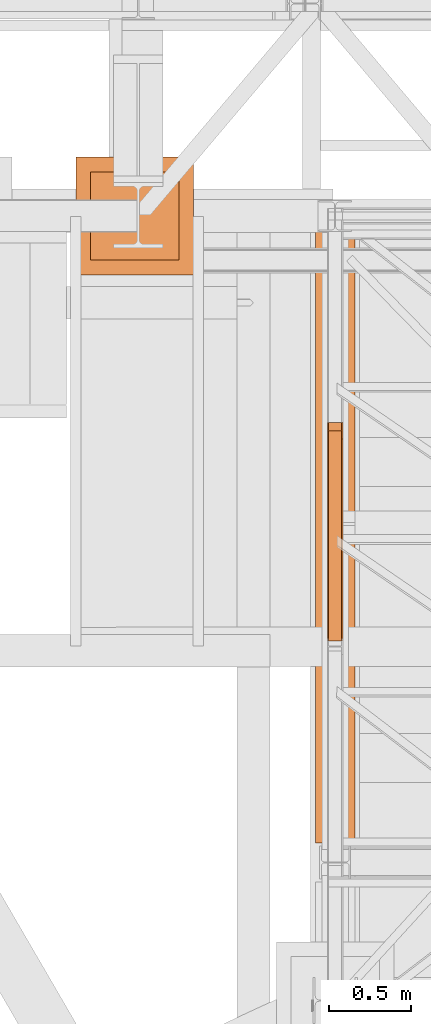
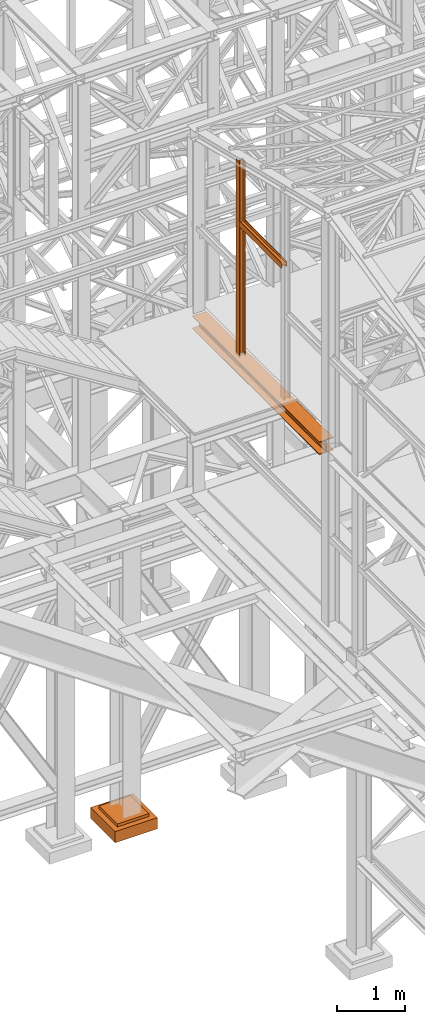
# One storey, part 30 of 208: 5 proxies.
"""IFC2X3 building model written with IfcOpenShell, lengths in millimetres."""

from ifc_helpers import new_model, entity, si_unit, converted_unit, frame, origin, origin_with_axes, place, context, subcontext, project, spatial, faceted_brep, element, save


model = new_model("IFC2X3")

# Units and contexts
model_context = context("Model", 3, precision=1e-05, world=origin())
plan_context = context("Plan", 3, precision=1e-05, world=origin())
body_context = subcontext(model_context, "Body", "Model", "MODEL_VIEW")
ifc_project = project(units=[si_unit("LENGTHUNIT", "METRE", prefix="MILLI"), converted_unit("PLANEANGLEUNIT", "DEGREE", entity("IfcPlaneAngleMeasure", 0.0174532925199433), si_unit("PLANEANGLEUNIT", "RADIAN"), dimensions=[0, 0, 0, 0, 0, 0, 0]), si_unit("AREAUNIT", "SQUARE_METRE"), si_unit("VOLUMEUNIT", "CUBIC_METRE")], contexts=[model_context, plan_context])

# Building, storey
building_placement = place(None, origin())
building = spatial("IfcBuilding", under=ifc_project, at=building_placement, CompositionType="COMPLEX")
storey_placement = place(building_placement, origin_with_axes())
storey = spatial("IfcBuildingStorey", under=building, at=storey_placement, Name="Geschoss", CompositionType="ELEMENT")

# Proxies
proxy_1_placement = place(storey_placement, frame((1150.25496814422, -19861.79723418248, 10824.99000200596), z_axis=(0.0, 0.0, 1.0), x_axis=(1.0, 0.0, 0.0)))
element("IfcBuildingElementProxy", 1, at=proxy_1_placement, inside=storey, context=body_context, shape_type="Brep", body=[
    faceted_brep([(8.009999999999991, 0.00999999999839929, 0.01000000000021828), (0.009999999999990905, 0.00999999999839929, 0.01000000000021828), (0.009999999999990905, 0.00999999999839929, 100.0100000000002), (8.009999999999991, 0.00999999999839929, 100.0100000000002), (8.009999999999991, 0.00999999999839929, 52.51000000000022), (88.00999999999999, 0.00999999999839929, 52.51000000000022), (88.00999999999999, 0.00999999999839929, 100.0100000000002), (96.00999999999999, 0.00999999999839929, 100.0100000000002), (96.00999999999999, 0.00999999999839929, 0.01000000000021828), (88.00999999999999, 0.00999999999839929, 0.01000000000021828), (88.00999999999999, 0.00999999999839929, 47.51000000000022), (8.009999999999991, 0.00999999999839929, 47.51000000000022), (0.009999999999990905, 0.00999999999839929, 0.01000000000021828), (8.009999999999991, 0.00999999999839929, 0.01000000000021828), (8.009999999999991, 1334.847202244597, 0.01000684652717609), (0.009999999999990905, 1334.847202244597, 0.01000684652717609), (0.009999999999990905, 0.00999999999839929, 100.0100000000002), (0.009999999999990905, 0.00999999999839929, 0.01000000000021828), (0.009999999999990905, 1334.847202244597, 0.01000684652717609), (0.009999999999990905, 1334.847202244597, 100.0100068465272), (8.009999999999991, 0.00999999999839929, 100.0100000000002), (0.009999999999990905, 0.00999999999839929, 100.0100000000002), (0.009999999999990905, 1334.847202244597, 100.0100068465272), (8.009999999999991, 1334.847202244597, 100.0100068465272), (8.009999999999991, 0.00999999999839929, 52.51000000000022), (8.009999999999991, 0.00999999999839929, 100.0100000000002), (8.009999999999991, 1334.847202244597, 100.0100068465272), (8.009999999999991, 1334.847202244597, 52.51000684652718), (88.00999999999999, 0.00999999999839929, 52.51000000000022), (8.009999999999991, 0.00999999999839929, 52.51000000000022), (8.009999999999991, 1334.847202244597, 52.51000684652718), (88.00999999999999, 1334.847202244597, 52.51000684652718), (88.00999999999999, 0.00999999999839929, 100.0100000000002), (88.00999999999999, 0.00999999999839929, 52.51000000000022), (88.00999999999999, 1334.847202244597, 52.51000684652718), (88.00999999999999, 1334.847202244597, 100.0100068465272), (96.00999999999999, 0.00999999999839929, 100.0100000000002), (88.00999999999999, 0.00999999999839929, 100.0100000000002), (88.00999999999999, 1334.847202244597, 100.0100068465272), (96.00999999999999, 1334.847202244597, 100.0100068465272), (96.00999999999999, 0.00999999999839929, 0.01000000000021828), (96.00999999999999, 0.00999999999839929, 100.0100000000002), (96.00999999999999, 1334.847202244597, 100.0100068465272), (96.00999999999999, 1334.847202244597, 0.01000684652717609), (88.00999999999999, 0.00999999999839929, 0.01000000000021828), (96.00999999999999, 0.00999999999839929, 0.01000000000021828), (96.00999999999999, 1334.847202244597, 0.01000684652717609), (88.00999999999999, 1334.847202244597, 0.01000684652717609), (88.00999999999999, 0.00999999999839929, 47.51000000000022), (88.00999999999999, 0.00999999999839929, 0.01000000000021828), (88.00999999999999, 1334.847202244597, 0.01000684652717609), (88.00999999999999, 1334.847202244597, 47.51000684652718), (8.009999999999991, 0.00999999999839929, 47.51000000000022), (88.00999999999999, 0.00999999999839929, 47.51000000000022), (88.00999999999999, 1334.847202244597, 47.51000684652718), (8.009999999999991, 1334.847202244597, 47.51000684652718), (8.009999999999991, 0.00999999999839929, 0.01000000000021828), (8.009999999999991, 0.00999999999839929, 47.51000000000022), (8.009999999999991, 1334.847202244597, 47.51000684652718), (8.009999999999991, 1334.847202244597, 0.01000684652717609), (8.009999999999991, 1334.847202244597, 0.01000684652717609), (8.009999999999991, 1334.847202244597, 47.51000684652718), (88.00999999999999, 1334.847202244597, 47.51000684652718), (88.00999999999999, 1334.847202244597, 0.01000684652717609), (96.00999999999999, 1334.847202244597, 0.01000684652717609), (96.00999999999999, 1334.847202244597, 100.0100068465272), (88.00999999999999, 1334.847202244597, 100.0100068465272), (88.00999999999999, 1334.847202244597, 52.51000684652718), (8.009999999999991, 1334.847202244597, 52.51000684652718), (8.009999999999991, 1334.847202244597, 100.0100068465272), (0.009999999999990905, 1334.847202244597, 100.0100068465272), (0.009999999999990905, 1334.847202244597, 0.01000684652717609)], [[[0, 1, 2, 3, 4, 5, 6, 7, 8, 9, 10, 11]], [[12, 13, 14, 15]], [[16, 17, 18, 19]], [[20, 21, 22, 23]], [[24, 25, 26, 27]], [[28, 29, 30, 31]], [[32, 33, 34, 35]], [[36, 37, 38, 39]], [[40, 41, 42, 43]], [[44, 45, 46, 47]], [[48, 49, 50, 51]], [[52, 53, 54, 55]], [[56, 57, 58, 59]], [[60, 61, 62, 63, 64, 65, 66, 67, 68, 69, 70, 71]]], orient=[[False], [False], [False], [False], [False], [False], [False], [False], [False], [False], [False], [False], [False], [False]]),
])
proxy_2_placement = place(storey_placement, frame((1150.25496814422, -18626.96003193789, 8484.990002086155), z_axis=(0.0, 0.0, 1.0), x_axis=(1.0, 0.0, 0.0)))
element("IfcBuildingElementProxy", 2, at=proxy_2_placement, inside=storey, context=body_context, shape_type="Brep", body=[
    faceted_brep([(8.009999999999991, 0.01000000000203727, 3504.259992333347), (0.009999999999990905, 0.01000000000203727, 3504.259992333347), (0.009999999999990905, 100.010000000002, 3504.259992333347), (8.009999999999991, 100.010000000002, 3504.259992333347), (8.009999999999991, 52.51000000000204, 3504.259992333347), (88.00999999999999, 52.51000000000204, 3504.259992333347), (88.00999999999999, 100.010000000002, 3504.259992333347), (96.00999999999999, 100.010000000002, 3504.259992333347), (96.00999999999999, 0.01000000000203727, 3504.259992333347), (88.00999999999999, 0.01000000000203727, 3504.259992333347), (88.00999999999999, 47.51000000000204, 3504.259992333347), (8.009999999999991, 47.51000000000204, 3504.259992333347), (0.009999999999990905, 0.01000000000203727, 3504.259992333347), (8.009999999999991, 0.01000000000203727, 3504.259992333347), (8.009999999999991, 0.01000000000203727, 0.01000000000021828), (0.009999999999990905, 0.01000000000203727, 0.01000000000021828), (0.009999999999990905, 100.010000000002, 3504.259992333347), (0.009999999999990905, 0.01000000000203727, 3504.259992333347), (0.009999999999990905, 0.01000000000203727, 0.01000000000021828), (0.009999999999990905, 100.0100000000057, 0.01000000000021828), (8.009999999999991, 100.010000000002, 3504.259992333347), (0.009999999999990905, 100.010000000002, 3504.259992333347), (0.009999999999990905, 100.0100000000057, 0.01000000000021828), (8.009999999999991, 100.0100000000057, 0.01000000000021828), (8.009999999999991, 52.51000000000204, 3504.259992333347), (8.009999999999991, 100.010000000002, 3504.259992333347), (8.009999999999991, 100.0100000000057, 0.01000000000021828), (8.009999999999991, 52.51000000000568, 0.01000000000021828), (88.00999999999999, 52.51000000000204, 3504.259992333347), (8.009999999999991, 52.51000000000204, 3504.259992333347), (8.009999999999991, 52.51000000000568, 0.01000000000021828), (88.00999999999999, 52.51000000000568, 0.01000000000021828), (88.00999999999999, 100.010000000002, 3504.259992333347), (88.00999999999999, 52.51000000000204, 3504.259992333347), (88.00999999999999, 52.51000000000568, 0.01000000000021828), (88.00999999999999, 100.0100000000057, 0.01000000000021828), (96.00999999999999, 100.010000000002, 3504.259992333347), (88.00999999999999, 100.010000000002, 3504.259992333347), (88.00999999999999, 100.0100000000057, 0.01000000000021828), (96.00999999999999, 100.0100000000057, 0.01000000000021828), (96.00999999999999, 0.01000000000203727, 3504.259992333347), (96.00999999999999, 100.010000000002, 3504.259992333347), (96.00999999999999, 100.0100000000057, 0.01000000000021828), (96.00999999999999, 0.01000000000203727, 0.01000000000021828), (88.00999999999999, 0.01000000000203727, 3504.259992333347), (96.00999999999999, 0.01000000000203727, 3504.259992333347), (96.00999999999999, 0.01000000000203727, 0.01000000000021828), (88.00999999999999, 0.01000000000203727, 0.01000000000021828), (88.00999999999999, 47.51000000000204, 3504.259992333347), (88.00999999999999, 0.01000000000203727, 3504.259992333347), (88.00999999999999, 0.01000000000203727, 0.01000000000021828), (88.00999999999999, 47.51000000000568, 0.01000000000021828), (8.009999999999991, 47.51000000000204, 3504.259992333347), (88.00999999999999, 47.51000000000204, 3504.259992333347), (88.00999999999999, 47.51000000000568, 0.01000000000021828), (8.009999999999991, 47.51000000000568, 0.01000000000021828), (8.009999999999991, 0.01000000000203727, 3504.259992333347), (8.009999999999991, 47.51000000000204, 3504.259992333347), (8.009999999999991, 47.51000000000568, 0.01000000000021828), (8.009999999999991, 0.01000000000203727, 0.01000000000021828), (8.009999999999991, 0.01000000000203727, 0.01000000000021828), (8.009999999999991, 47.51000000000568, 0.01000000000021828), (88.00999999999999, 47.51000000000568, 0.01000000000021828), (88.00999999999999, 0.01000000000203727, 0.01000000000021828), (96.00999999999999, 0.01000000000203727, 0.01000000000021828), (96.00999999999999, 100.0100000000057, 0.01000000000021828), (88.00999999999999, 100.0100000000057, 0.01000000000021828), (88.00999999999999, 52.51000000000568, 0.01000000000021828), (8.009999999999991, 52.51000000000568, 0.01000000000021828), (8.009999999999991, 100.0100000000057, 0.01000000000021828), (0.009999999999990905, 100.0100000000057, 0.01000000000021828), (0.009999999999990905, 0.01000000000203727, 0.01000000000021828)], [[[0, 1, 2, 3, 4, 5, 6, 7, 8, 9, 10, 11]], [[12, 13, 14, 15]], [[16, 17, 18, 19]], [[20, 21, 22, 23]], [[24, 25, 26, 27]], [[28, 29, 30, 31]], [[32, 33, 34, 35]], [[36, 37, 38, 39]], [[40, 41, 42, 43]], [[44, 45, 46, 47]], [[48, 49, 50, 51]], [[52, 53, 54, 55]], [[56, 57, 58, 59]], [[60, 61, 62, 63, 64, 65, 66, 67, 68, 69, 70, 71]]], orient=[[False], [False], [False], [False], [False], [False], [False], [False], [False], [False], [False], [False], [False], [False]]),
])
proxy_3_placement = place(storey_placement, frame((1150.25496814422, -19861.79723418248, 10824.99000200596), z_axis=(0.0, 0.0, 1.0), x_axis=(1.0, 0.0, 0.0)))
element("IfcBuildingElementProxy", 3, at=proxy_3_placement, inside=storey, context=body_context, shape_type="Brep", body=[
    faceted_brep([(8.009999999999991, 0.00999999999839929, 0.01000000000021828), (0.009999999999990905, 0.00999999999839929, 0.01000000000021828), (0.009999999999990905, 0.00999999999839929, 100.0100000000002), (8.009999999999991, 0.00999999999839929, 100.0100000000002), (8.009999999999991, 0.00999999999839929, 52.51000000000022), (88.00999999999999, 0.00999999999839929, 52.51000000000022), (88.00999999999999, 0.00999999999839929, 100.0100000000002), (96.00999999999999, 0.00999999999839929, 100.0100000000002), (96.00999999999999, 0.00999999999839929, 0.01000000000021828), (88.00999999999999, 0.00999999999839929, 0.01000000000021828), (88.00999999999999, 0.00999999999839929, 47.51000000000022), (8.009999999999991, 0.00999999999839929, 47.51000000000022), (0.009999999999990905, 0.00999999999839929, 0.01000000000021828), (8.009999999999991, 0.00999999999839929, 0.01000000000021828), (8.009999999999991, 1334.847202244597, 0.01000684652717609), (0.009999999999990905, 1334.847202244597, 0.01000684652717609), (0.009999999999990905, 0.00999999999839929, 100.0100000000002), (0.009999999999990905, 0.00999999999839929, 0.01000000000021828), (0.009999999999990905, 1334.847202244597, 0.01000684652717609), (0.009999999999990905, 1334.847202244597, 100.0100068465272), (8.009999999999991, 0.00999999999839929, 100.0100000000002), (0.009999999999990905, 0.00999999999839929, 100.0100000000002), (0.009999999999990905, 1334.847202244597, 100.0100068465272), (8.009999999999991, 1334.847202244597, 100.0100068465272), (8.009999999999991, 0.00999999999839929, 52.51000000000022), (8.009999999999991, 0.00999999999839929, 100.0100000000002), (8.009999999999991, 1334.847202244597, 100.0100068465272), (8.009999999999991, 1334.847202244597, 52.51000684652718), (88.00999999999999, 0.00999999999839929, 52.51000000000022), (8.009999999999991, 0.00999999999839929, 52.51000000000022), (8.009999999999991, 1334.847202244597, 52.51000684652718), (88.00999999999999, 1334.847202244597, 52.51000684652718), (88.00999999999999, 0.00999999999839929, 100.0100000000002), (88.00999999999999, 0.00999999999839929, 52.51000000000022), (88.00999999999999, 1334.847202244597, 52.51000684652718), (88.00999999999999, 1334.847202244597, 100.0100068465272), (96.00999999999999, 0.00999999999839929, 100.0100000000002), (88.00999999999999, 0.00999999999839929, 100.0100000000002), (88.00999999999999, 1334.847202244597, 100.0100068465272), (96.00999999999999, 1334.847202244597, 100.0100068465272), (96.00999999999999, 0.00999999999839929, 0.01000000000021828), (96.00999999999999, 0.00999999999839929, 100.0100000000002), (96.00999999999999, 1334.847202244597, 100.0100068465272), (96.00999999999999, 1334.847202244597, 0.01000684652717609), (88.00999999999999, 0.00999999999839929, 0.01000000000021828), (96.00999999999999, 0.00999999999839929, 0.01000000000021828), (96.00999999999999, 1334.847202244597, 0.01000684652717609), (88.00999999999999, 1334.847202244597, 0.01000684652717609), (88.00999999999999, 0.00999999999839929, 47.51000000000022), (88.00999999999999, 0.00999999999839929, 0.01000000000021828), (88.00999999999999, 1334.847202244597, 0.01000684652717609), (88.00999999999999, 1334.847202244597, 47.51000684652718), (8.009999999999991, 0.00999999999839929, 47.51000000000022), (88.00999999999999, 0.00999999999839929, 47.51000000000022), (88.00999999999999, 1334.847202244597, 47.51000684652718), (8.009999999999991, 1334.847202244597, 47.51000684652718), (8.009999999999991, 0.00999999999839929, 0.01000000000021828), (8.009999999999991, 0.00999999999839929, 47.51000000000022), (8.009999999999991, 1334.847202244597, 47.51000684652718), (8.009999999999991, 1334.847202244597, 0.01000684652717609), (8.009999999999991, 1334.847202244597, 0.01000684652717609), (8.009999999999991, 1334.847202244597, 47.51000684652718), (88.00999999999999, 1334.847202244597, 47.51000684652718), (88.00999999999999, 1334.847202244597, 0.01000684652717609), (96.00999999999999, 1334.847202244597, 0.01000684652717609), (96.00999999999999, 1334.847202244597, 100.0100068465272), (88.00999999999999, 1334.847202244597, 100.0100068465272), (88.00999999999999, 1334.847202244597, 52.51000684652718), (8.009999999999991, 1334.847202244597, 52.51000684652718), (8.009999999999991, 1334.847202244597, 100.0100068465272), (0.009999999999990905, 1334.847202244597, 100.0100068465272), (0.009999999999990905, 1334.847202244597, 0.01000684652717609)], [[[0, 1, 2, 3, 4, 5, 6, 7, 8, 9, 10, 11]], [[12, 13, 14, 15]], [[16, 17, 18, 19]], [[20, 21, 22, 23]], [[24, 25, 26, 27]], [[28, 29, 30, 31]], [[32, 33, 34, 35]], [[36, 37, 38, 39]], [[40, 41, 42, 43]], [[44, 45, 46, 47]], [[48, 49, 50, 51]], [[52, 53, 54, 55]], [[56, 57, 58, 59]], [[60, 61, 62, 63, 64, 65, 66, 67, 68, 69, 70, 71]]], orient=[[False], [False], [False], [False], [False], [False], [False], [False], [False], [False], [False], [False], [False], [False]]),
])
proxy_4_placement = place(storey_placement, frame((-388.6908527149287, -17622.57439531565, -315.01), z_axis=(0.0, 0.0, 1.0), x_axis=(1.0, 0.0, 0.0)))
element("IfcBuildingElementProxy", 4, at=proxy_4_placement, inside=storey, context=body_context, shape_type="Brep", body=[
    faceted_brep([(630.01, 630.0099999999984, 250.01), (630.01, 90.0099999999984, 250.01), (90.00999999999999, 90.0099999999984, 250.01), (90.00999999999999, 630.0099999999984, 250.01), (630.01, 630.0099999999984, 200.01), (630.01, 90.0099999999984, 200.01), (630.01, 90.0099999999984, 250.01), (630.01, 630.0099999999984, 250.01), (90.00999999999999, 630.0099999999984, 200.01), (630.01, 630.0099999999984, 200.01), (630.01, 630.0099999999984, 250.01), (90.00999999999999, 630.0099999999984, 250.01), (90.00999999999999, 90.0099999999984, 200.01), (90.00999999999999, 630.0099999999984, 200.01), (90.00999999999999, 630.0099999999984, 250.01), (90.00999999999999, 90.0099999999984, 250.01), (630.01, 90.0099999999984, 200.01), (90.00999999999999, 90.0099999999984, 200.01), (90.00999999999999, 90.0099999999984, 250.01), (630.01, 90.0099999999984, 250.01), (720.01, 0.00999999999839929, 0.009999999999990905), (720.01, 720.0099999999984, 0.009999999999990905), (0.009999999999990905, 720.0099999999984, 0.009999999999990905), (0.009999999999990905, 0.00999999999839929, 0.009999999999990905), (720.01, 720.0099999999984, 200.01), (720.01, 0.00999999999839929, 200.01), (0.009999999999990905, 0.00999999999839929, 200.01), (0.009999999999990905, 720.0099999999984, 200.01), (90.00999999999999, 90.0099999999984, 200.01), (630.01, 90.0099999999984, 200.01), (630.01, 630.0099999999984, 200.01), (90.00999999999999, 630.0099999999984, 200.01), (720.01, 720.0099999999984, 0.009999999999990905), (720.01, 0.00999999999839929, 0.009999999999990905), (720.01, 0.00999999999839929, 200.01), (720.01, 720.0099999999984, 200.01), (0.009999999999990905, 720.0099999999984, 0.009999999999990905), (720.01, 720.0099999999984, 0.009999999999990905), (720.01, 720.0099999999984, 200.01), (0.009999999999990905, 720.0099999999984, 200.01), (0.009999999999990905, 0.00999999999839929, 0.009999999999990905), (0.009999999999990905, 720.0099999999984, 0.009999999999990905), (0.009999999999990905, 720.0099999999984, 200.01), (0.009999999999990905, 0.00999999999839929, 200.01), (720.01, 0.00999999999839929, 0.009999999999990905), (0.009999999999990905, 0.00999999999839929, 0.009999999999990905), (0.009999999999990905, 0.00999999999839929, 200.01), (720.01, 0.00999999999839929, 200.01)], [[[0, 1, 2, 3]], [[4, 5, 6, 7]], [[8, 9, 10, 11]], [[12, 13, 14, 15]], [[16, 17, 18, 19]], [[20, 21, 22, 23]], [[24, 25, 26, 27], [28, 29, 30, 31]], [[32, 33, 34, 35]], [[36, 37, 38, 39]], [[40, 41, 42, 43]], [[44, 45, 46, 47]]], orient=[[False], [False], [False], [False], [False], [False], [False, False], [False], [False], [False], [False]]),
])
proxy_5_placement = place(storey_placement, frame((1078.254963760293, -21097.57438554951, 8254.989997913835), z_axis=(0.0, 0.0, 1.0), x_axis=(1.0, 0.0, 0.0)))
element("IfcBuildingElementProxy", 5, at=proxy_5_placement, inside=storey, context=body_context, shape_type="Brep", body=[
    faceted_brep([(0.009999999999990905, 0.00999999999839929, 0.01000000000021828), (240.0100095367423, 0.00999999999839929, 0.01000000000021828), (240.0100095367441, 3740.009997648187, 0.01000000000021828), (0.01000000000180989, 3740.009997648187, 0.01000000000021828), (0.009999999999990905, 0.00999999999839929, 12.0100019669535), (0.009999999999990905, 0.00999999999839929, 0.01000000000021828), (0.01000000000180989, 3740.009997648187, 0.01000000000021828), (0.01000000000180989, 3740.009997648187, 12.0100019669535), (95.26000303983687, 0.00999999999839929, 12.0100019669535), (0.009999999999990905, 0.00999999999839929, 12.0100019669535), (0.01000000000180989, 3740.009997648187, 12.0100019669535), (95.2600030398387, 3740.009997648187, 12.0100019669535), (106.1284490099549, 0.00999999999839929, 14.18530328035376), (95.26000303983687, 0.00999999999839929, 12.0100019669535), (95.2600030398387, 3740.009997648187, 12.0100019669535), (106.1284490099567, 3740.009997648187, 14.18530328035376), (114.0846986493468, 0.00999999999839929, 22.14155478239081), (106.1284490099549, 0.00999999999839929, 14.18530328035376), (106.1284490099567, 3740.009997648187, 14.18530328035376), (114.0846986493486, 3740.009997648187, 22.14155478239081), (116.26000461936, 0.00999999999839929, 33.00999982118628), (114.0846986493468, 0.00999999999839929, 22.14155478239081), (114.0846986493486, 3740.009997648187, 22.14155478239081), (116.2600046193618, 3740.009997648187, 33.00999982118628), (116.26000461936, 0.00999999999839929, 197.0100043511357), (116.26000461936, 0.00999999999839929, 33.00999982118628), (116.2600046193618, 3740.009997648187, 33.00999982118628), (116.2600046193618, 3740.009997648187, 197.0100043511357), (114.0846986493468, 0.00999999999839929, 207.8784493899311), (116.26000461936, 0.00999999999839929, 197.0100043511357), (116.2600046193618, 3740.009997648187, 197.0100043511357), (114.0846986493486, 3740.009997648187, 207.8784493899311), (106.1284490099549, 0.00999999999839929, 215.8347008919682), (114.0846986493468, 0.00999999999839929, 207.8784493899311), (114.0846986493486, 3740.009997648187, 207.8784493899311), (106.1284490099567, 3740.009997648187, 215.8347008919682), (95.26000303983687, 0.00999999999839929, 218.0100022053684), (106.1284490099549, 0.00999999999839929, 215.8347008919682), (106.1284490099567, 3740.009997648187, 215.8347008919682), (95.2600030398387, 3740.009997648187, 218.0100022053684), (0.009999999999990905, 0.00999999999839929, 218.0100022053684), (95.26000303983687, 0.00999999999839929, 218.0100022053684), (95.2600030398387, 3740.009997648187, 218.0100022053684), (0.01000000000180989, 3740.009997648187, 218.0100022053684), (0.009999999999990905, 0.00999999999839929, 230.0100041723235), (0.009999999999990905, 0.00999999999839929, 218.0100022053684), (0.01000000000180989, 3740.009997648187, 218.0100022053684), (0.01000000000180989, 3740.009997648187, 230.0100041723217), (240.0100095367423, 0.00999999999839929, 230.0100041723217), (0.009999999999990905, 0.00999999999839929, 230.0100041723235), (0.01000000000180989, 3740.009997648187, 230.0100041723217), (240.0100095367441, 3740.009997648187, 230.0100041723217), (240.0100095367432, 0.00999999999839929, 218.0100022053684), (240.0100095367423, 0.00999999999839929, 230.0100041723217), (240.0100095367441, 3740.009997648187, 230.0100041723217), (240.0100095367441, 3740.009997648187, 218.0100022053684), (144.7600064969063, 0.00999999999839929, 218.0100022053703), (240.0100095367432, 0.00999999999839929, 218.0100022053684), (240.0100095367441, 3740.009997648187, 218.0100022053684), (144.7600064969072, 3740.009997648187, 218.0100022053703), (133.8915605267864, 0.00999999999839929, 215.8347008919682), (144.7600064969063, 0.00999999999839929, 218.0100022053703), (144.7600064969072, 3740.009997648187, 218.0100022053703), (133.8915605267882, 3740.009997648187, 215.8347008919682), (125.9353108873945, 0.00999999999839929, 207.8784493899311), (133.8915605267864, 0.00999999999839929, 215.8347008919682), (133.8915605267882, 3740.009997648187, 215.8347008919682), (125.9353108873963, 3740.009997648187, 207.8784493899311), (123.7600049173832, 0.00999999999839929, 197.0100043511338), (125.9353108873945, 0.00999999999839929, 207.8784493899311), (125.9353108873963, 3740.009997648187, 207.8784493899311), (123.760004917385, 3740.009997648187, 197.0100043511338), (123.7600049173814, 0.00999999999839929, 33.00999982118628), (123.7600049173832, 0.00999999999839929, 197.0100043511338), (123.760004917385, 3740.009997648187, 197.0100043511338), (123.7600049173841, 3740.009997648187, 33.00999982118628), (125.9353108873954, 0.00999999999839929, 22.14155478239081), (123.7600049173814, 0.00999999999839929, 33.00999982118628), (123.7600049173841, 3740.009997648187, 33.00999982118628), (125.9353108873972, 3740.009997648187, 22.14155478239081), (133.8915605267864, 0.00999999999839929, 14.18530328035376), (125.9353108873954, 0.00999999999839929, 22.14155478239081), (125.9353108873972, 3740.009997648187, 22.14155478239081), (133.8915605267891, 3740.009997648187, 14.18530328035376), (144.7600064969054, 0.00999999999839929, 12.0100019669535), (133.8915605267864, 0.00999999999839929, 14.18530328035376), (133.8915605267891, 3740.009997648187, 14.18530328035376), (144.7600064969072, 3740.009997648187, 12.0100019669535), (240.0100095367423, 0.00999999999839929, 12.0100019669535), (144.7600064969054, 0.00999999999839929, 12.0100019669535), (144.7600064969072, 3740.009997648187, 12.0100019669535), (240.0100095367441, 3740.009997648187, 12.0100019669535), (240.0100095367423, 0.00999999999839929, 0.01000000000021828), (240.0100095367423, 0.00999999999839929, 12.0100019669535), (240.0100095367441, 3740.009997648187, 12.0100019669535), (240.0100095367441, 3740.009997648187, 0.01000000000021828), (0.01000000000180989, 3740.009997648187, 0.01000000000021828), (240.0100095367441, 3740.009997648187, 0.01000000000021828), (240.0100095367441, 3740.009997648187, 12.0100019669535), (144.7600064969072, 3740.009997648187, 12.0100019669535), (133.8915605267891, 3740.009997648187, 14.18530328035376), (125.9353108873972, 3740.009997648187, 22.14155478239081), (123.7600049173841, 3740.009997648187, 33.00999982118628), (123.760004917385, 3740.009997648187, 197.0100043511338), (125.9353108873963, 3740.009997648187, 207.8784493899311), (133.8915605267882, 3740.009997648187, 215.8347008919682), (144.7600064969072, 3740.009997648187, 218.0100022053703), (240.0100095367441, 3740.009997648187, 218.0100022053684), (240.0100095367441, 3740.009997648187, 230.0100041723217), (0.01000000000180989, 3740.009997648187, 230.0100041723217), (0.01000000000180989, 3740.009997648187, 218.0100022053684), (95.2600030398387, 3740.009997648187, 218.0100022053684), (106.1284490099567, 3740.009997648187, 215.8347008919682), (114.0846986493486, 3740.009997648187, 207.8784493899311), (116.2600046193618, 3740.009997648187, 197.0100043511357), (116.2600046193618, 3740.009997648187, 33.00999982118628), (114.0846986493486, 3740.009997648187, 22.14155478239081), (106.1284490099567, 3740.009997648187, 14.18530328035376), (95.2600030398387, 3740.009997648187, 12.0100019669535), (0.01000000000180989, 3740.009997648187, 12.0100019669535), (240.0100095367423, 0.00999999999839929, 0.01000000000021828), (0.009999999999990905, 0.00999999999839929, 0.01000000000021828), (0.009999999999990905, 0.00999999999839929, 12.0100019669535), (95.26000303983687, 0.00999999999839929, 12.0100019669535), (106.1284490099549, 0.00999999999839929, 14.18530328035376), (114.0846986493468, 0.00999999999839929, 22.14155478239081), (116.26000461936, 0.00999999999839929, 33.00999982118628), (116.26000461936, 0.00999999999839929, 197.0100043511357), (114.0846986493468, 0.00999999999839929, 207.8784493899311), (106.1284490099549, 0.00999999999839929, 215.8347008919682), (95.26000303983687, 0.00999999999839929, 218.0100022053684), (0.009999999999990905, 0.00999999999839929, 218.0100022053684), (0.009999999999990905, 0.00999999999839929, 230.0100041723235), (240.0100095367423, 0.00999999999839929, 230.0100041723217), (240.0100095367432, 0.00999999999839929, 218.0100022053684), (144.7600064969063, 0.00999999999839929, 218.0100022053703), (133.8915605267864, 0.00999999999839929, 215.8347008919682), (125.9353108873945, 0.00999999999839929, 207.8784493899311), (123.7600049173832, 0.00999999999839929, 197.0100043511338), (123.7600049173814, 0.00999999999839929, 33.00999982118628), (125.9353108873954, 0.00999999999839929, 22.14155478239081), (133.8915605267864, 0.00999999999839929, 14.18530328035376), (144.7600064969054, 0.00999999999839929, 12.0100019669535), (240.0100095367423, 0.00999999999839929, 12.0100019669535)], [[[0, 1, 2, 3]], [[4, 5, 6, 7]], [[8, 9, 10, 11]], [[12, 13, 14, 15]], [[16, 17, 18, 19]], [[20, 21, 22, 23]], [[24, 25, 26, 27]], [[28, 29, 30, 31]], [[32, 33, 34, 35]], [[36, 37, 38, 39]], [[40, 41, 42, 43]], [[44, 45, 46, 47]], [[48, 49, 50, 51]], [[52, 53, 54, 55]], [[56, 57, 58, 59]], [[60, 61, 62, 63]], [[64, 65, 66, 67]], [[68, 69, 70, 71]], [[72, 73, 74, 75]], [[76, 77, 78, 79]], [[80, 81, 82, 83]], [[84, 85, 86, 87]], [[88, 89, 90, 91]], [[92, 93, 94, 95]], [[96, 97, 98, 99, 100, 101, 102, 103, 104, 105, 106, 107, 108, 109, 110, 111, 112, 113, 114, 115, 116, 117, 118, 119]], [[120, 121, 122, 123, 124, 125, 126, 127, 128, 129, 130, 131, 132, 133, 134, 135, 136, 137, 138, 139, 140, 141, 142, 143]]], orient=[[False], [False], [False], [False], [False], [False], [False], [False], [False], [False], [False], [False], [False], [False], [False], [False], [False], [False], [False], [False], [False], [False], [False], [False], [False], [False]]),
])

save(model, "model.ifc")
